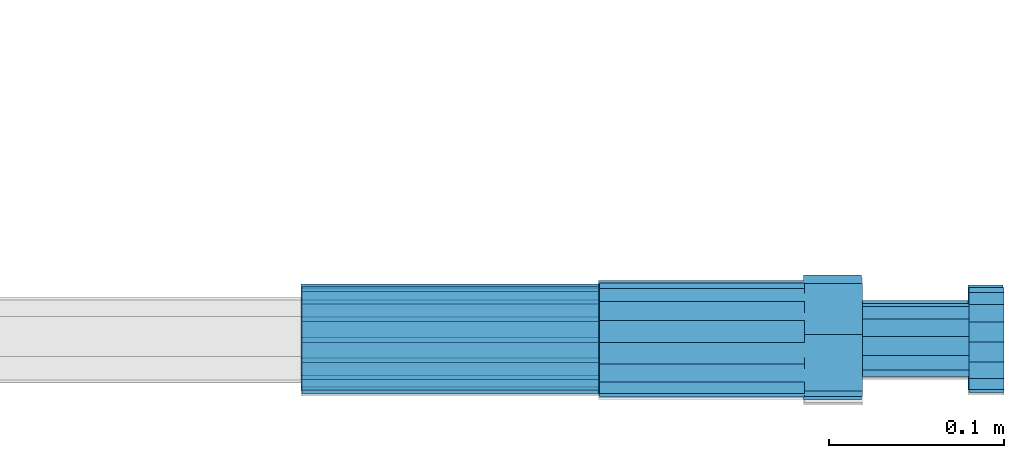
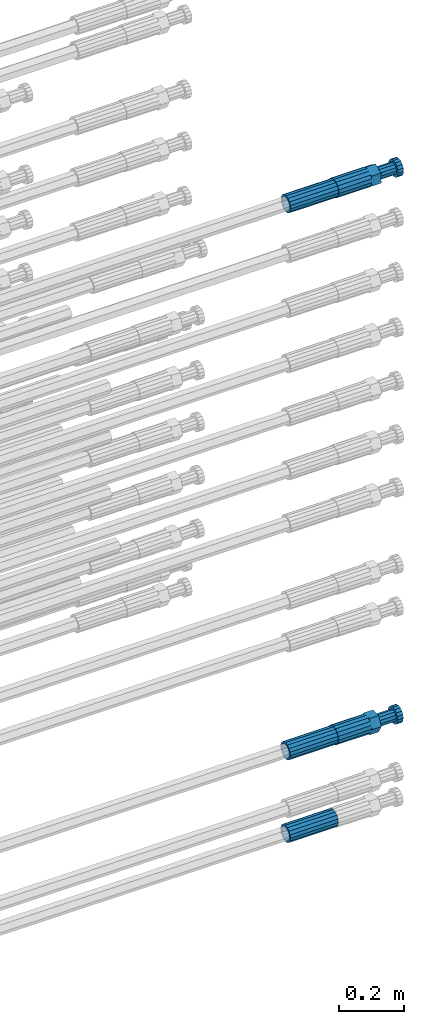
# One storey, part 105 of 177: 5 beams.
"""IFC2X3 building model written with IfcOpenShell, lengths in millimetres."""

from ifc_helpers import new_model, si_unit, frame, origin_with_axes, place, context, subcontext, project, spatial, faceted_brep, material, type_object, element, save


model = new_model("IFC2X3")

# Units and contexts
model_context_1 = context("Model", 3, precision=1e-05, world=origin_with_axes())
model_context_2 = context("Model", 3, precision=1e-05, world=origin_with_axes())
body_context = subcontext(model_context_2, "Body", "Model", "MODEL_VIEW")
ifc_project = project(units=[si_unit("LENGTHUNIT", "METRE", prefix="MILLI"), si_unit("AREAUNIT", "SQUARE_METRE"), si_unit("VOLUMEUNIT", "CUBIC_METRE"), si_unit("MASSUNIT", "GRAM", prefix="KILO"), si_unit("TIMEUNIT", "SECOND"), si_unit("PLANEANGLEUNIT", "RADIAN"), si_unit("SOLIDANGLEUNIT", "STERADIAN"), si_unit("THERMODYNAMICTEMPERATUREUNIT", "DEGREE_CELSIUS"), si_unit("LUMINOUSINTENSITYUNIT", "LUMEN")], contexts=[model_context_1])

# Site, building, storey
site_placement = place(None, origin_with_axes())
site = spatial("IfcSite", under=ifc_project, at=site_placement, CompositionType="ELEMENT")
building_placement = place(site_placement, origin_with_axes())
building = spatial("IfcBuilding", under=site, at=building_placement, Name="Undefined", CompositionType="ELEMENT")
storey_placement = place(building_placement, origin_with_axes())
storey = spatial("IfcBuildingStorey", under=building, at=storey_placement, Name="Undefined", CompositionType="ELEMENT", Elevation=0.0)

# Beams
ifc_material = material(Name="STEEL/S275")
beam_type_1 = type_object("IfcBeamType", PredefinedType="NOTDEFINED")
beam_1_placement = place(storey_placement, frame((2039349.51584468, 6205099.56001969, 20959.9946311984), z_axis=(0.0, 0.422618263993424, -0.906307785986187), x_axis=(1.0, 0.0, 0.0)))
element("IfcBeam", 1, at=beam_1_placement, inside=storey, type_object=beam_type_1, material=ifc_material, Name="AG40N", context=body_context, shape_type="Brep", body=[
    faceted_brep([(0.0, -23.5000000001164, -9.31322574615479e-10), (0.0, -21.7111690140155, 8.99306066054851), (170.0, -21.7111690140155, 8.99306066054851), (170.0, -23.5, 0.0), (0.0, -16.6170093578839, 16.6170093575493), (170.0, -16.6170093578839, 16.6170093575493), (0.0, -8.99306066057943, 21.7111690137535), (170.0, -8.99306066057943, 21.7111690137535), (0.0, 1.16415321826935e-10, 23.5), (170.0, 0.0, 23.5), (0.0, 8.99306066057943, 21.7111690137535), (170.0, 8.99306066057943, 21.7111690137535), (0.0, 16.6170093578839, 16.6170093575493), (170.0, 16.6170093578839, 16.6170093575493), (0.0, 21.7111690140155, 8.99306066054851), (170.0, 21.7111690140155, 8.99306066054851), (0.0, 23.5000000001164, -9.31322574615479e-10), (170.0, 23.5, 0.0), (0.0, 21.7111690140155, -8.99306066054851), (170.0, 21.7111690140155, -8.99306066054851), (0.0, 16.6170093578839, -16.6170093575493), (170.0, 16.6170093578839, -16.6170093575493), (0.0, 8.99306066057943, -21.7111690137535), (170.0, 8.99306066057943, -21.7111690137535), (0.0, 1.16415321826935e-10, -23.5000000009313), (170.0, 0.0, -23.5), (0.0, -8.99306066057943, -21.7111690137535), (170.0, -8.99306066057943, -21.7111690137535), (0.0, -16.6170093578839, -16.6170093575493), (170.0, -16.6170093578839, -16.6170093575493), (0.0, -21.7111690140155, -8.99306066054851), (170.0, -21.7111690140155, -8.99306066054851), (0.0, -30.5, 0.0), (0.0, -28.1783257415937, -11.6718446873128), (170.0, -28.1783257415937, -11.6718446873128), (170.0, -30.5, 0.0), (0.0, -21.5667568261888, -21.5667568258941), (170.0, -21.5667568261888, -21.5667568258941), (0.0, -11.6718446871346, -28.1783257415518), (170.0, -11.6718446871346, -28.1783257415518), (0.0, 0.0, -30.5), (170.0, 0.0, -30.5), (0.0, 11.6718446871346, -28.1783257415518), (170.0, 11.6718446871346, -28.1783257415518), (0.0, 21.5667568261888, -21.5667568258941), (170.0, 21.5667568261888, -21.5667568258941), (0.0, 28.1783257415937, -11.6718446873128), (170.0, 28.1783257415937, -11.6718446873128), (0.0, 30.5, 0.0), (170.0, 30.5, 0.0), (0.0, 28.1783257415937, 11.6718446873128), (170.0, 28.1783257415937, 11.6718446873128), (0.0, 21.5667568261888, 21.5667568258941), (170.0, 21.5667568261888, 21.5667568258941), (0.0, 11.6718446871346, 28.1783257415518), (170.0, 11.6718446871346, 28.1783257415518), (0.0, 0.0, 30.5), (170.0, 0.0, 30.5), (0.0, -11.6718446871346, 28.1783257415518), (170.0, -11.6718446871346, 28.1783257415518), (0.0, -21.5667568261888, 21.5667568258941), (170.0, -21.5667568261888, 21.5667568258941), (0.0, -28.1783257415937, 11.6718446873128), (170.0, -28.1783257415937, 11.6718446873128)], [[[0, 1, 2, 3]], [[1, 4, 5, 2]], [[4, 6, 7, 5]], [[6, 8, 9, 7]], [[8, 10, 11, 9]], [[10, 12, 13, 11]], [[12, 14, 15, 13]], [[14, 16, 17, 15]], [[16, 18, 19, 17]], [[18, 20, 21, 19]], [[20, 22, 23, 21]], [[22, 24, 25, 23]], [[24, 26, 27, 25]], [[26, 28, 29, 27]], [[28, 30, 31, 29]], [[30, 0, 3, 31]], [[32, 33, 34, 35]], [[33, 36, 37, 34]], [[36, 38, 39, 37]], [[38, 40, 41, 39]], [[40, 42, 43, 41]], [[42, 44, 45, 43]], [[44, 46, 47, 45]], [[46, 48, 49, 47]], [[48, 50, 51, 49]], [[50, 52, 53, 51]], [[52, 54, 55, 53]], [[54, 56, 57, 55]], [[56, 58, 59, 57]], [[58, 60, 61, 59]], [[60, 62, 63, 61]], [[62, 32, 35, 63]], [[37, 39, 41, 43, 45, 47, 49, 51, 53, 55, 57, 59, 61, 63, 35, 34], [5, 7, 9, 11, 13, 15, 17, 19, 21, 23, 25, 27, 29, 31, 3, 2]], [[62, 60, 58, 56, 54, 52, 50, 48, 46, 44, 42, 40, 38, 36, 33, 32], [30, 28, 26, 24, 22, 20, 18, 16, 14, 12, 10, 8, 6, 4, 1, 0]]]),
])
beam_2_placement = place(storey_placement, frame((2039349.02038002, 6205100.98587169, 18907.9868004768), z_axis=(0.0, 0.0, -1.0), x_axis=(1.0, 0.0, 0.0)))
element("IfcBeam", 2, at=beam_2_placement, inside=storey, type_object=beam_type_1, material=ifc_material, Name="AG40N", context=body_context, shape_type="Brep", body=[
    faceted_brep([(0.0, -23.5000000001164, -9.31322574615479e-10), (0.0, -21.7111690140155, 8.99306066054851), (170.0, -21.7111690140155, 8.99306066054851), (170.0, -23.5, 0.0), (0.0, -16.6170093578839, 16.6170093575493), (170.0, -16.6170093578839, 16.6170093575493), (0.0, -8.99306066057943, 21.7111690137535), (170.0, -8.99306066057943, 21.7111690137535), (0.0, 1.16415321826935e-10, 23.5), (170.0, 0.0, 23.5), (0.0, 8.99306066057943, 21.7111690137535), (170.0, 8.99306066057943, 21.7111690137535), (0.0, 16.6170093578839, 16.6170093575493), (170.0, 16.6170093578839, 16.6170093575493), (0.0, 21.7111690140155, 8.99306066054851), (170.0, 21.7111690140155, 8.99306066054851), (0.0, 23.5000000001164, -9.31322574615479e-10), (170.0, 23.5, 0.0), (0.0, 21.7111690140155, -8.99306066054851), (170.0, 21.7111690140155, -8.99306066054851), (0.0, 16.6170093578839, -16.6170093575493), (170.0, 16.6170093578839, -16.6170093575493), (0.0, 8.99306066057943, -21.7111690137535), (170.0, 8.99306066057943, -21.7111690137535), (0.0, 1.16415321826935e-10, -23.5000000009313), (170.0, 0.0, -23.5), (0.0, -8.99306066057943, -21.7111690137535), (170.0, -8.99306066057943, -21.7111690137535), (0.0, -16.6170093578839, -16.6170093575493), (170.0, -16.6170093578839, -16.6170093575493), (0.0, -21.7111690140155, -8.99306066054851), (170.0, -21.7111690140155, -8.99306066054851), (0.0, -30.5, 0.0), (0.0, -28.1783257415937, -11.6718446873128), (170.0, -28.1783257415937, -11.6718446873128), (170.0, -30.5, 0.0), (0.0, -21.5667568261888, -21.5667568258941), (170.0, -21.5667568261888, -21.5667568258941), (0.0, -11.6718446871346, -28.1783257415518), (170.0, -11.6718446871346, -28.1783257415518), (0.0, 0.0, -30.5), (170.0, 0.0, -30.5), (0.0, 11.6718446871346, -28.1783257415518), (170.0, 11.6718446871346, -28.1783257415518), (0.0, 21.5667568261888, -21.5667568258941), (170.0, 21.5667568261888, -21.5667568258941), (0.0, 28.1783257415937, -11.6718446873128), (170.0, 28.1783257415937, -11.6718446873128), (0.0, 30.5, 0.0), (170.0, 30.5, 0.0), (0.0, 28.1783257415937, 11.6718446873128), (170.0, 28.1783257415937, 11.6718446873128), (0.0, 21.5667568261888, 21.5667568258941), (170.0, 21.5667568261888, 21.5667568258941), (0.0, 11.6718446871346, 28.1783257415518), (170.0, 11.6718446871346, 28.1783257415518), (0.0, 0.0, 30.5), (170.0, 0.0, 30.5), (0.0, -11.6718446871346, 28.1783257415518), (170.0, -11.6718446871346, 28.1783257415518), (0.0, -21.5667568261888, 21.5667568258941), (170.0, -21.5667568261888, 21.5667568258941), (0.0, -28.1783257415937, 11.6718446873128), (170.0, -28.1783257415937, 11.6718446873128)], [[[0, 1, 2, 3]], [[1, 4, 5, 2]], [[4, 6, 7, 5]], [[6, 8, 9, 7]], [[8, 10, 11, 9]], [[10, 12, 13, 11]], [[12, 14, 15, 13]], [[14, 16, 17, 15]], [[16, 18, 19, 17]], [[18, 20, 21, 19]], [[20, 22, 23, 21]], [[22, 24, 25, 23]], [[24, 26, 27, 25]], [[26, 28, 29, 27]], [[28, 30, 31, 29]], [[30, 0, 3, 31]], [[32, 33, 34, 35]], [[33, 36, 37, 34]], [[36, 38, 39, 37]], [[38, 40, 41, 39]], [[40, 42, 43, 41]], [[42, 44, 45, 43]], [[44, 46, 47, 45]], [[46, 48, 49, 47]], [[48, 50, 51, 49]], [[50, 52, 53, 51]], [[52, 54, 55, 53]], [[54, 56, 57, 55]], [[56, 58, 59, 57]], [[58, 60, 61, 59]], [[60, 62, 63, 61]], [[62, 32, 35, 63]], [[37, 39, 41, 43, 45, 47, 49, 51, 53, 55, 57, 59, 61, 63, 35, 34], [5, 7, 9, 11, 13, 15, 17, 19, 21, 23, 25, 27, 29, 31, 3, 2]], [[62, 60, 58, 56, 54, 52, 50, 48, 46, 44, 42, 40, 38, 36, 33, 32], [30, 28, 26, 24, 22, 20, 18, 16, 14, 12, 10, 8, 6, 4, 1, 0]]]),
])
beam_3_placement = place(storey_placement, frame((2039349.04037948, 6205100.91588036, 18597.9968004305), z_axis=(0.0, 0.0, -1.0), x_axis=(1.0, 0.0, 0.0)))
element("IfcBeam", 3, at=beam_3_placement, inside=storey, type_object=beam_type_1, material=ifc_material, Name="AG40N", context=body_context, shape_type="Brep", body=[
    faceted_brep([(0.0, -23.5000000001164, -9.31322574615479e-10), (0.0, -21.7111690140155, 8.99306066054851), (170.0, -21.7111690140155, 8.99306066054851), (170.0, -23.5, 0.0), (0.0, -16.6170093578839, 16.6170093575493), (170.0, -16.6170093578839, 16.6170093575493), (0.0, -8.99306066057943, 21.7111690137535), (170.0, -8.99306066057943, 21.7111690137535), (0.0, 1.16415321826935e-10, 23.5), (170.0, 0.0, 23.5), (0.0, 8.99306066057943, 21.7111690137535), (170.0, 8.99306066057943, 21.7111690137535), (0.0, 16.6170093578839, 16.6170093575493), (170.0, 16.6170093578839, 16.6170093575493), (0.0, 21.7111690140155, 8.99306066054851), (170.0, 21.7111690140155, 8.99306066054851), (0.0, 23.5000000001164, -9.31322574615479e-10), (170.0, 23.5, 0.0), (0.0, 21.7111690140155, -8.99306066054851), (170.0, 21.7111690140155, -8.99306066054851), (0.0, 16.6170093578839, -16.6170093575493), (170.0, 16.6170093578839, -16.6170093575493), (0.0, 8.99306066057943, -21.7111690137535), (170.0, 8.99306066057943, -21.7111690137535), (0.0, 1.16415321826935e-10, -23.5000000009313), (170.0, 0.0, -23.5), (0.0, -8.99306066057943, -21.7111690137535), (170.0, -8.99306066057943, -21.7111690137535), (0.0, -16.6170093578839, -16.6170093575493), (170.0, -16.6170093578839, -16.6170093575493), (0.0, -21.7111690140155, -8.99306066054851), (170.0, -21.7111690140155, -8.99306066054851), (0.0, -30.5, 0.0), (0.0, -28.1783257415937, -11.6718446873128), (170.0, -28.1783257415937, -11.6718446873128), (170.0, -30.5, 0.0), (0.0, -21.5667568261888, -21.5667568258941), (170.0, -21.5667568261888, -21.5667568258941), (0.0, -11.6718446871346, -28.1783257415518), (170.0, -11.6718446871346, -28.1783257415518), (0.0, 0.0, -30.5), (170.0, 0.0, -30.5), (0.0, 11.6718446871346, -28.1783257415518), (170.0, 11.6718446871346, -28.1783257415518), (0.0, 21.5667568261888, -21.5667568258941), (170.0, 21.5667568261888, -21.5667568258941), (0.0, 28.1783257415937, -11.6718446873128), (170.0, 28.1783257415937, -11.6718446873128), (0.0, 30.5, 0.0), (170.0, 30.5, 0.0), (0.0, 28.1783257415937, 11.6718446873128), (170.0, 28.1783257415937, 11.6718446873128), (0.0, 21.5667568261888, 21.5667568258941), (170.0, 21.5667568261888, 21.5667568258941), (0.0, 11.6718446871346, 28.1783257415518), (170.0, 11.6718446871346, 28.1783257415518), (0.0, 0.0, 30.5), (170.0, 0.0, 30.5), (0.0, -11.6718446871346, 28.1783257415518), (170.0, -11.6718446871346, 28.1783257415518), (0.0, -21.5667568261888, 21.5667568258941), (170.0, -21.5667568261888, 21.5667568258941), (0.0, -28.1783257415937, 11.6718446873128), (170.0, -28.1783257415937, 11.6718446873128)], [[[0, 1, 2, 3]], [[1, 4, 5, 2]], [[4, 6, 7, 5]], [[6, 8, 9, 7]], [[8, 10, 11, 9]], [[10, 12, 13, 11]], [[12, 14, 15, 13]], [[14, 16, 17, 15]], [[16, 18, 19, 17]], [[18, 20, 21, 19]], [[20, 22, 23, 21]], [[22, 24, 25, 23]], [[24, 26, 27, 25]], [[26, 28, 29, 27]], [[28, 30, 31, 29]], [[30, 0, 3, 31]], [[32, 33, 34, 35]], [[33, 36, 37, 34]], [[36, 38, 39, 37]], [[38, 40, 41, 39]], [[40, 42, 43, 41]], [[42, 44, 45, 43]], [[44, 46, 47, 45]], [[46, 48, 49, 47]], [[48, 50, 51, 49]], [[50, 52, 53, 51]], [[52, 54, 55, 53]], [[54, 56, 57, 55]], [[56, 58, 59, 57]], [[58, 60, 61, 59]], [[60, 62, 63, 61]], [[62, 32, 35, 63]], [[37, 39, 41, 43, 45, 47, 49, 51, 53, 55, 57, 59, 61, 63, 35, 34], [5, 7, 9, 11, 13, 15, 17, 19, 21, 23, 25, 27, 29, 31, 3, 2]], [[62, 60, 58, 56, 54, 52, 50, 48, 46, 44, 42, 40, 38, 36, 33, 32], [30, 28, 26, 24, 22, 20, 18, 16, 14, 12, 10, 8, 6, 4, 1, 0]]]),
])
beam_type_2 = type_object("IfcBeamType", Name="ROD65", PredefinedType="NOTDEFINED")
beam_4_placement = place(storey_placement, frame((2039519.51584459, 6205099.5600197, 20959.9946311866), z_axis=(0.0, 0.422618263993424, -0.906307785986187), x_axis=(1.0, 0.0, 0.0)))
element("IfcBeam", 4, at=beam_4_placement, inside=storey, type_object=beam_type_2, material=ifc_material, Name="AGB40", ObjectType="ROD65", context=body_context, shape_type="Brep", body=[
    faceted_brep([(117.0, 8.17543110251427, 30.873805644922), (117.0, 17.8250000001863, 30.873805644922), (117.0, 22.0056958701462, 23.6326279877685), (117.0, 12.4372115517035, 30.0260848065373), (117.0, -17.8250000001863, 30.873805644922), (150.200000000186, -17.8250000001863, 30.873805644922), (150.200000000186, 17.8250000001863, 30.873805644922), (117.0, -8.17543110251427, 30.873805644922), (117.0, -12.4372115517035, 30.0260848065373), (117.0, -22.0056958701462, 23.6326279877685), (117.0, -35.6500000003725, 0.0), (150.200000000186, -35.6500000003725, 0.0), (117.0, -30.8443150008097, 8.32369058486074), (117.0, -32.5, 0.0), (117.0, -30.8443150008097, -8.32369058462791), (117.0, -17.8250000001863, -30.873805644922), (150.200000000186, -17.8250000001863, -30.873805644922), (117.0, -22.0056958701462, -23.6326279877685), (117.0, -12.4372115517035, -30.0260848065373), (117.0, -8.17543110251427, -30.873805644922), (117.0, 17.8250000001863, -30.873805644922), (150.200000000186, 17.8250000001863, -30.873805644922), (117.0, 8.17543110251427, -30.873805644922), (117.0, 22.0056958701462, -23.6326279877685), (117.0, 12.4372115517035, -30.0260848065373), (117.0, 35.6500000003725, 0.0), (150.200000000186, 35.6500000003725, 0.0), (117.0, 30.8443150008097, -8.32369058486074), (117.0, 30.8443150008097, 8.32369058462791), (117.0, 32.5, 0.0), (0.0, -22.9809703892097, 22.9809703885621), (0.0, -30.0260848058388, 12.4372115518636), (117.0, -30.0260848067701, 12.4372115519363), (117.0, -22.9809703882784, 22.9809703885112), (-2.3283064365387e-10, 22.9809703892097, -22.9809703885639), (-4.65661287307739e-10, 30.0260848077014, -12.4372115518672), (117.0, 30.0260848067701, -12.4372115519363), (117.0, 22.9809703882784, -22.9809703885112), (-2.3283064365387e-10, -30.0260848067701, -12.4372115518672), (-2.3283064365387e-10, -22.9809703892097, -22.9809703885621), (117.0, -22.9809703882784, -22.9809703885112), (117.0, -30.0260848067701, -12.4372115519363), (-2.3283064365387e-10, -12.4372115507722, 30.0260848066137), (-2.3283064365387e-10, 9.31322574615479e-10, 32.4999999999982), (-2.3283064365387e-10, 12.4372115526348, 30.0260848066137), (0.0, 22.9809703892097, 22.9809703885621), (-2.3283064365387e-10, 30.0260848077014, 12.4372115518636), (-2.3283064365387e-10, 32.5, 0.0), (-2.3283064365387e-10, 12.4372115526348, -30.0260848066173), (-2.3283064365387e-10, 9.31322574615479e-10, -32.5), (-2.3283064365387e-10, -12.4372115517035, -30.0260848066173), (-4.65661287307739e-10, -32.4999999990687, -1.81898940354586e-12), (117.0, 22.9809703882784, 22.9809703885112), (117.0, 30.0260848067701, 12.4372115519363), (117.0, 0.0, -32.5), (117.0, 0.0, 32.5), (150.200000000186, 10.5, -18.1865334794857), (150.200000000186, 0.0, -21.0), (150.200000000186, -10.5, -18.1865334794857), (150.200000000186, -18.18653347902, -10.5), (150.200000000186, -21.0, 0.0), (150.200000000186, -18.18653347902, 10.5), (150.200000000186, -10.5, 18.1865334794857), (150.200000000186, 0.0, 21.0), (150.200000000186, 10.5, 18.1865334794857), (150.200000000186, 18.18653347902, 10.5), (150.200000000186, 21.0, 0.0), (150.200000000186, 18.18653347902, -10.5), (210.980000000447, -10.5, 18.1865334794857), (210.980000000447, -18.18653347902, 10.5), (210.980000000447, 0.0, 21.0), (210.980000000447, 10.5, 18.1865334794857), (210.980000000447, 18.18653347902, 10.5), (210.980000000447, 21.0, 0.0), (210.980000000447, 18.18653347902, -10.5), (210.980000000447, 10.5, -18.1865334794857), (210.980000000447, 0.0, -21.0), (210.980000000447, -10.5, -18.1865334794857), (210.980000000447, -18.18653347902, -10.5), (210.980000000447, -21.0, 0.0), (211.001368442696, -27.7269937992096, -11.491116326768), (211.003082550167, -21.2238094303757, -21.223815418547), (231.002518367059, -21.2131944671273, -21.2132004550658), (231.000804259587, -27.7163788359612, -11.4805013632867), (211.001368440451, -11.4911085031927, -27.7269970395137), (231.000804257343, -11.4804935399443, -27.7163820760325), (210.996487071217, -0.0106065049767494, -30.0106107392348), (230.995922888109, 8.45827162265778e-06, -29.9999957757536), (210.989181586672, 11.46989420522, -27.7269970329944), (230.988617403564, 11.4805091684684, -27.7163820695132), (210.980564180623, 21.2025914648548, -21.2238154064398), (230.979999997515, 21.2132064281031, -21.2132004429586), (210.971946775022, 27.7057703435421, -11.4911163107026), (230.971382591913, 27.7163853067905, -11.4805013472214), (210.96464129175, 29.9893808094785, -0.0106149562634528), (230.964077108642, 29.9999957727268, 7.21774995326996e-09), (210.959759924415, 27.7057638689876, 11.4698863970116), (230.959195741307, 27.7163788322359, 11.4805013604928), (210.958045816944, 21.2025795001537, 21.2025854887906), (230.957481633835, 21.213194463402, 21.2132004522718), (210.95975992666, 11.4698785729706, 27.7057671097573), (230.959195743551, 11.480493536219, 27.7163820732385), (210.964641295894, -0.010623425245285, 29.9893808094785), (230.964077112785, -8.46199691295624e-06, 29.9999957729597), (210.971946780439, -11.4911241354421, 27.705767103238), (230.97138259733, -11.4805091721937, 27.7163820667192), (210.980564186488, -21.2238213950768, 21.2025854766835), (230.980000003379, -21.2132064318284, 21.2132004401647), (210.989181592089, -27.7270002737641, 11.4698863809463), (230.988617408981, -27.7163853105158, 11.4805013444275), (210.996487075361, -30.0106107397005, -0.0106149734929204), (230.995922892253, -29.9999957764521, -1.00117176771164e-08)], [[[0, 1, 2, 3]], [[4, 5, 6, 1, 0, 7]], [[4, 7, 8, 9]], [[10, 11, 5, 4, 9, 12]], [[10, 12, 13, 14]], [[15, 16, 11, 10, 14, 17]], [[15, 17, 18, 19]], [[20, 21, 16, 15, 19, 22]], [[23, 20, 22, 24]], [[25, 26, 21, 20, 23, 27]], [[28, 25, 27, 29]], [[30, 31, 32, 33]], [[34, 35, 36, 37]], [[38, 39, 40, 41]], [[31, 30, 42, 43, 44, 45, 46, 47, 35, 34, 48, 49, 50, 39, 38, 51]], [[46, 45, 52, 53]], [[29, 47, 46, 53, 28]], [[27, 36, 35, 47, 29]], [[23, 37, 36, 27]], [[24, 48, 34, 37, 23]], [[22, 54, 49, 48, 24]], [[19, 54, 22]], [[18, 50, 49, 54, 19]], [[17, 40, 39, 50, 18]], [[14, 41, 40, 17]], [[13, 51, 38, 41, 14]], [[12, 32, 31, 51, 13]], [[9, 33, 32, 12]], [[8, 42, 30, 33, 9]], [[7, 55, 43, 42, 8]], [[0, 55, 7]], [[3, 44, 43, 55, 0]], [[2, 52, 45, 44, 3]], [[28, 53, 52, 2]], [[1, 6, 26, 25, 28, 2]], [[5, 11, 16, 21, 26, 6], [56, 57, 58, 59, 60, 61, 62, 63, 64, 65, 66, 67]], [[68, 62, 61, 69]], [[70, 63, 62, 68]], [[71, 64, 63, 70]], [[72, 65, 64, 71]], [[73, 66, 65, 72]], [[74, 67, 66, 73]], [[75, 56, 67, 74]], [[76, 57, 56, 75]], [[77, 58, 57, 76]], [[78, 59, 58, 77]], [[79, 60, 59, 78]], [[69, 61, 60, 79]], [[80, 81, 82, 83]], [[81, 84, 85, 82]], [[84, 86, 87, 85]], [[86, 88, 89, 87]], [[88, 90, 91, 89]], [[90, 92, 93, 91]], [[92, 94, 95, 93]], [[94, 96, 97, 95]], [[96, 98, 99, 97]], [[98, 100, 101, 99]], [[100, 102, 103, 101]], [[102, 104, 105, 103]], [[104, 106, 107, 105]], [[106, 108, 109, 107]], [[108, 110, 111, 109]], [[82, 85, 87, 89, 91, 93, 95, 97, 99, 101, 103, 105, 107, 109, 111, 83]], [[110, 80, 83, 111]], [[108, 106, 104, 102, 100, 98, 96, 94, 92, 90, 88, 86, 84, 81, 80, 110], [74, 73, 72, 71, 70, 68, 69, 79, 78, 77, 76, 75]]]),
])
beam_5_placement = place(storey_placement, frame((2039519.02038002, 6205100.98587191, 18907.9868004767), z_axis=(0.0, 0.0, -1.0), x_axis=(1.0, 0.0, 0.0)))
element("IfcBeam", 5, at=beam_5_placement, inside=storey, type_object=beam_type_2, material=ifc_material, Name="AGB40", ObjectType="ROD65", context=body_context, shape_type="Brep", body=[
    faceted_brep([(117.0, 8.17543110251427, 30.873805644922), (117.0, 17.8250000001863, 30.873805644922), (117.0, 22.0056958701462, 23.6326279877685), (117.0, 12.4372115517035, 30.0260848065373), (117.0, -17.8250000001863, 30.873805644922), (150.200000000186, -17.8250000001863, 30.873805644922), (150.200000000186, 17.8250000001863, 30.873805644922), (117.0, -8.17543110251427, 30.873805644922), (117.0, -12.4372115517035, 30.0260848065373), (117.0, -22.0056958701462, 23.6326279877685), (117.0, -35.6500000003725, 0.0), (150.200000000186, -35.6500000003725, 0.0), (117.0, -30.8443150008097, 8.32369058486074), (117.0, -32.5, 0.0), (117.0, -30.8443150008097, -8.32369058462791), (117.0, -17.8250000001863, -30.873805644922), (150.200000000186, -17.8250000001863, -30.873805644922), (117.0, -22.0056958701462, -23.6326279877685), (117.0, -12.4372115517035, -30.0260848065373), (117.0, -8.17543110251427, -30.873805644922), (117.0, 17.8250000001863, -30.873805644922), (150.200000000186, 17.8250000001863, -30.873805644922), (117.0, 8.17543110251427, -30.873805644922), (117.0, 22.0056958701462, -23.6326279877685), (117.0, 12.4372115517035, -30.0260848065373), (117.0, 35.6500000003725, 0.0), (150.200000000186, 35.6500000003725, 0.0), (117.0, 30.8443150008097, -8.32369058486074), (117.0, 30.8443150008097, 8.32369058462791), (117.0, 32.5, 0.0), (0.0, -22.9809703892097, 22.9809703885621), (0.0, -30.0260848058388, 12.4372115518636), (117.0, -30.0260848067701, 12.4372115519363), (117.0, -22.9809703882784, 22.9809703885112), (-2.3283064365387e-10, 22.9809703892097, -22.9809703885639), (-4.65661287307739e-10, 30.0260848077014, -12.4372115518672), (117.0, 30.0260848067701, -12.4372115519363), (117.0, 22.9809703882784, -22.9809703885112), (-2.3283064365387e-10, -30.0260848067701, -12.4372115518672), (-2.3283064365387e-10, -22.9809703892097, -22.9809703885621), (117.0, -22.9809703882784, -22.9809703885112), (117.0, -30.0260848067701, -12.4372115519363), (-2.3283064365387e-10, -12.4372115507722, 30.0260848066137), (-2.3283064365387e-10, 9.31322574615479e-10, 32.4999999999982), (-2.3283064365387e-10, 12.4372115526348, 30.0260848066137), (0.0, 22.9809703892097, 22.9809703885621), (-2.3283064365387e-10, 30.0260848077014, 12.4372115518636), (-2.3283064365387e-10, 32.5, 0.0), (-2.3283064365387e-10, 12.4372115526348, -30.0260848066173), (-2.3283064365387e-10, 9.31322574615479e-10, -32.5), (-2.3283064365387e-10, -12.4372115517035, -30.0260848066173), (-4.65661287307739e-10, -32.4999999990687, -1.81898940354586e-12), (117.0, 22.9809703882784, 22.9809703885112), (117.0, 30.0260848067701, 12.4372115519363), (117.0, 0.0, -32.5), (117.0, 0.0, 32.5), (150.200000000186, 10.5, -18.1865334794857), (150.200000000186, 0.0, -21.0), (150.200000000186, -10.5, -18.1865334794857), (150.200000000186, -18.18653347902, -10.5), (150.200000000186, -21.0, 0.0), (150.200000000186, -18.18653347902, 10.5), (150.200000000186, -10.5, 18.1865334794857), (150.200000000186, 0.0, 21.0), (150.200000000186, 10.5, 18.1865334794857), (150.200000000186, 18.18653347902, 10.5), (150.200000000186, 21.0, 0.0), (150.200000000186, 18.18653347902, -10.5), (210.980000000447, -18.18653347902, 10.5), (210.980000000447, -21.0, 0.0), (210.980000000447, -10.5, 18.1865334794857), (210.980000000447, 0.0, 21.0), (210.980000000447, 10.5, 18.1865334794857), (210.980000000447, 18.18653347902, 10.5), (210.980000000447, 21.0, 0.0), (210.980000000447, 18.18653347902, -10.5), (210.980000000447, 10.5, -18.1865334794857), (210.980000000447, 0.0, -21.0), (210.980000000447, -10.5, -18.1865334794857), (210.980000000447, -18.18653347902, -10.5), (211.001368442696, -27.7269937992096, -11.491116326768), (211.003082550167, -21.2238094303757, -21.223815418547), (231.002518367059, -21.2131944671273, -21.2132004550658), (231.000804259587, -27.7163788359612, -11.4805013632867), (211.001368440451, -11.4911085031927, -27.7269970395137), (231.000804257343, -11.4804935399443, -27.7163820760325), (210.996487071217, -0.0106065049767494, -30.0106107392348), (230.995922888109, 8.45827162265778e-06, -29.9999957757536), (210.989181586672, 11.46989420522, -27.7269970329944), (230.988617403564, 11.4805091684684, -27.7163820695132), (210.980564180623, 21.2025914648548, -21.2238154064398), (230.979999997515, 21.2132064281031, -21.2132004429586), (210.971946775022, 27.7057703435421, -11.4911163107026), (230.971382591913, 27.7163853067905, -11.4805013472214), (210.96464129175, 29.9893808094785, -0.0106149562634528), (230.964077108642, 29.9999957727268, 7.21774995326996e-09), (210.959759924415, 27.7057638689876, 11.4698863970116), (230.959195741307, 27.7163788322359, 11.4805013604928), (210.958045816944, 21.2025795001537, 21.2025854887906), (230.957481633835, 21.213194463402, 21.2132004522718), (210.95975992666, 11.4698785729706, 27.7057671097573), (230.959195743551, 11.480493536219, 27.7163820732385), (210.964641295894, -0.010623425245285, 29.9893808094785), (230.964077112785, -8.46199691295624e-06, 29.9999957729597), (210.971946780439, -11.4911241354421, 27.705767103238), (230.97138259733, -11.4805091721937, 27.7163820667192), (210.980564186488, -21.2238213950768, 21.2025854766835), (230.980000003379, -21.2132064318284, 21.2132004401647), (210.989181592089, -27.7270002737641, 11.4698863809463), (230.988617408981, -27.7163853105158, 11.4805013444275), (210.996487075361, -30.0106107397005, -0.0106149734929204), (230.995922892253, -29.9999957764521, -1.00117176771164e-08)], [[[0, 1, 2, 3]], [[4, 5, 6, 1, 0, 7]], [[4, 7, 8, 9]], [[10, 11, 5, 4, 9, 12]], [[10, 12, 13, 14]], [[15, 16, 11, 10, 14, 17]], [[15, 17, 18, 19]], [[20, 21, 16, 15, 19, 22]], [[23, 20, 22, 24]], [[25, 26, 21, 20, 23, 27]], [[28, 25, 27, 29]], [[30, 31, 32, 33]], [[34, 35, 36, 37]], [[38, 39, 40, 41]], [[31, 30, 42, 43, 44, 45, 46, 47, 35, 34, 48, 49, 50, 39, 38, 51]], [[46, 45, 52, 53]], [[29, 47, 46, 53, 28]], [[27, 36, 35, 47, 29]], [[23, 37, 36, 27]], [[24, 48, 34, 37, 23]], [[22, 54, 49, 48, 24]], [[19, 54, 22]], [[18, 50, 49, 54, 19]], [[17, 40, 39, 50, 18]], [[14, 41, 40, 17]], [[13, 51, 38, 41, 14]], [[12, 32, 31, 51, 13]], [[9, 33, 32, 12]], [[8, 42, 30, 33, 9]], [[7, 55, 43, 42, 8]], [[0, 55, 7]], [[3, 44, 43, 55, 0]], [[2, 52, 45, 44, 3]], [[28, 53, 52, 2]], [[1, 6, 26, 25, 28, 2]], [[5, 11, 16, 21, 26, 6], [56, 57, 58, 59, 60, 61, 62, 63, 64, 65, 66, 67]], [[68, 61, 60, 69]], [[70, 62, 61, 68]], [[71, 63, 62, 70]], [[72, 64, 63, 71]], [[73, 65, 64, 72]], [[74, 66, 65, 73]], [[75, 67, 66, 74]], [[76, 56, 67, 75]], [[77, 57, 56, 76]], [[78, 58, 57, 77]], [[79, 59, 58, 78]], [[69, 60, 59, 79]], [[80, 81, 82, 83]], [[81, 84, 85, 82]], [[84, 86, 87, 85]], [[86, 88, 89, 87]], [[88, 90, 91, 89]], [[90, 92, 93, 91]], [[92, 94, 95, 93]], [[94, 96, 97, 95]], [[96, 98, 99, 97]], [[98, 100, 101, 99]], [[100, 102, 103, 101]], [[102, 104, 105, 103]], [[104, 106, 107, 105]], [[106, 108, 109, 107]], [[108, 110, 111, 109]], [[82, 85, 87, 89, 91, 93, 95, 97, 99, 101, 103, 105, 107, 109, 111, 83]], [[110, 80, 83, 111]], [[108, 106, 104, 102, 100, 98, 96, 94, 92, 90, 88, 86, 84, 81, 80, 110], [75, 74, 73, 72, 71, 70, 68, 69, 79, 78, 77, 76]]]),
])

save(model, "model.ifc")
